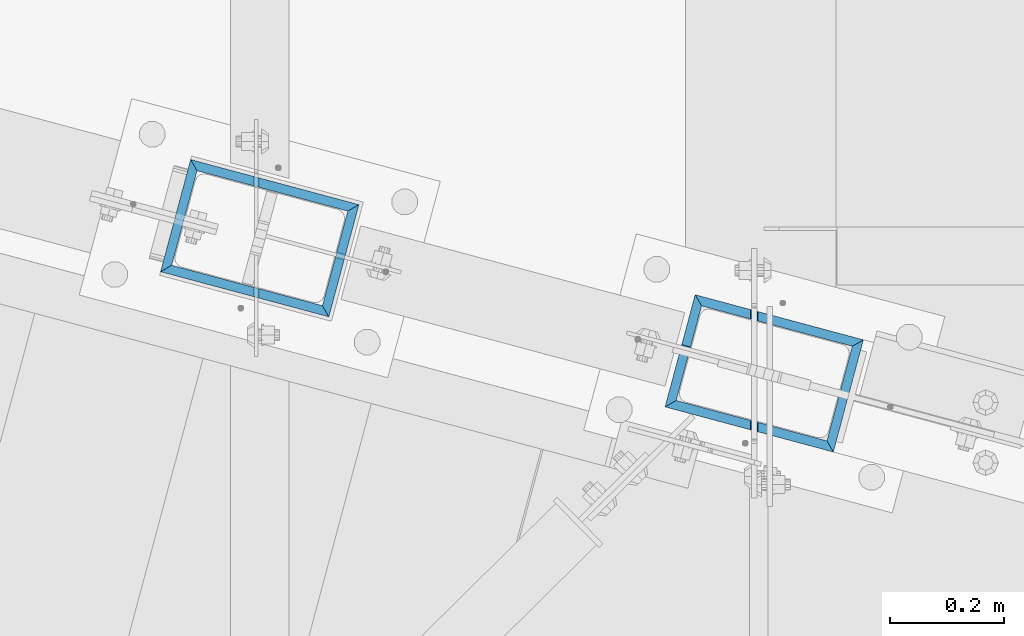
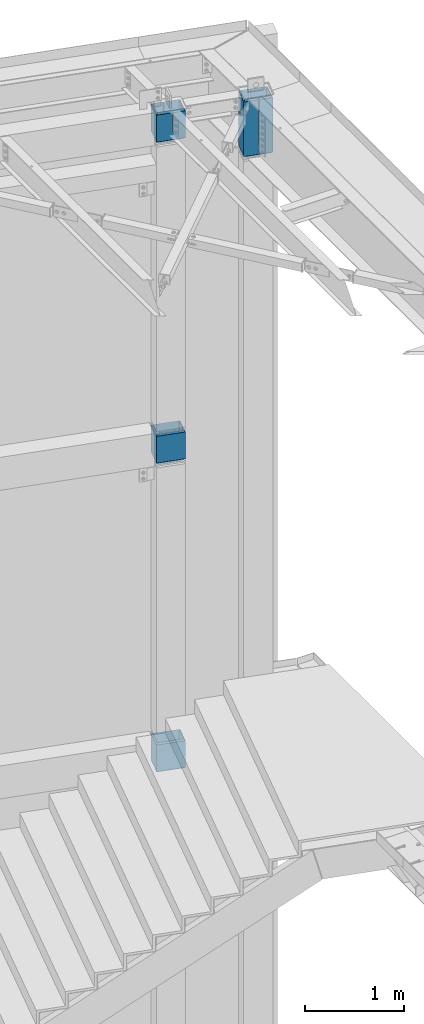
# One storey, part 977 of 1763: 4 columns, 2 elements without a shape of their own.
"""IFC2X3 building model written with IfcOpenShell, lengths in millimetres."""

from ifc_helpers import new_model, si_unit, frame, origin_with_axes, place, context, subcontext, project, spatial, faceted_brep, material, type_object, element, aggregate, save


model = new_model("IFC2X3")

# Units and contexts
model_context = context("Model", 3, precision=1e-05, world=origin_with_axes())
body_context = subcontext(model_context, "Body", "Model", "MODEL_VIEW")
ifc_project = project(units=[si_unit("LENGTHUNIT", "METRE", prefix="MILLI"), si_unit("AREAUNIT", "SQUARE_METRE"), si_unit("VOLUMEUNIT", "CUBIC_METRE"), si_unit("MASSUNIT", "GRAM", prefix="KILO"), si_unit("TIMEUNIT", "SECOND"), si_unit("PLANEANGLEUNIT", "RADIAN"), si_unit("SOLIDANGLEUNIT", "STERADIAN"), si_unit("THERMODYNAMICTEMPERATUREUNIT", "DEGREE_CELSIUS"), si_unit("LUMINOUSINTENSITYUNIT", "LUMEN")], contexts=[model_context])

# Site, building, storey
site_placement = place(None, origin_with_axes())
site = spatial("IfcSite", under=ifc_project, at=site_placement, CompositionType="ELEMENT")
building_placement = place(site_placement, origin_with_axes())
building = spatial("IfcBuilding", under=site, at=building_placement, Name="Undefined", CompositionType="ELEMENT")
storey_placement = place(building_placement, origin_with_axes())
storey = spatial("IfcBuildingStorey", under=building, at=storey_placement, Name="Undefined", CompositionType="ELEMENT", Elevation=0.0)

# Assembly, columns
assembly_1_placement = place(storey_placement, origin_with_axes())
assembly_1 = element("IfcElementAssembly", 1, at=assembly_1_placement, inside=storey, Name="COLUMN", AssemblyPlace="NOTDEFINED", PredefinedType="RIGID_FRAME")
ifc_material = material()
column_type = type_object("IfcColumnType", Name="HSS12X8X5/8", PredefinedType="NOTDEFINED")
column_1_placement = place(assembly_1_placement, frame((-22546.3296169582, 62092.5154188236, 12061.825), z_axis=(-0.965913267114846, 0.258865912030774, 0.0), x_axis=(0.0, 0.0, 1.0)))
column_1 = element("IfcColumn", 2, at=column_1_placement, type_object=column_type, material=ifc_material, Name="COLUMN", ObjectType="HSS12X8X5/8", context=body_context, shape_type="Brep", body=[
    faceted_brep([(365.125000005713, -85.724999991653, 136.524999990441), (349.2499999836, -101.600000015751, 152.399999996545), (349.249999996966, -101.60000000002, -15.7242657489624), (365.125000028824, -85.7250000000276, -11.4697467589649), (365.12499999055, 85.7250000058993, 136.525000005378), (365.12499998278, 85.7249999999331, 34.4790585103037), (349.249999996588, 101.599999999933, 38.7335775331376), (349.249999927195, 101.599999999868, 152.400000000212), (365.125000007893, 11.1191243688081, -136.524999999827), (349.249999997488, 11.1198946284858, -152.399999999834), (349.249999996875, 101.600000000057, -152.399999999776), (365.124999988529, 85.7250000000349, -136.524999999776), (365.124999983111, 85.7249999999331, 24.6179250700661), (349.249999996588, 101.599999999948, 28.8724440929145), (365.125000033029, -85.7249999999549, -136.524999999885), (349.249999997412, -101.599999999933, -152.399999999907), (349.249999997495, 1.59489499857591, -152.399999999841), (365.125000010366, 1.59412473888369, -136.524999999834), (365.125000029155, -85.7250000000204, -21.3308801992025), (349.249999996966, -101.60000000002, -25.5853991891854), (207.962499676918, 1.59412469829113, -136.5249999999), (207.962499661577, 1.59489496210881, -152.3999999999), (206.490806284746, 1.82798829382227, -152.3999999999), (206.490806300088, 1.82721802999004, -136.5249999999), (205.163172509408, 2.50445149033476, -152.3999999999), (205.16317252475, 2.50368122649525, -136.524999999907), (204.109556379663, 3.55806762077555, -152.3999999999), (204.109556395004, 3.55729735695058, -136.524999999907), (203.433093183266, 4.88570139733201, -152.3999999999), (203.433093198608, 4.88493113349978, -136.5249999999), (203.199999851075, 6.35739477576863, -152.3999999999), (203.199999866416, 6.35662451194366, -136.5249999999), (203.433093182502, 7.82908815434348, -152.3999999999), (203.433093197844, 7.82831789051124, -136.5249999999), (204.109556378211, 9.15672193124192, -152.3999999999), (204.109556393552, 9.15595166741696, -136.5249999999), (205.163172507409, 10.2103380622284, -152.3999999999), (205.163172522751, 10.2095677983962, -136.5249999999), (206.490806282394, 10.8868012594176, -152.399999999892), (206.490806297736, 10.8860309955926, -136.524999999892), (207.962499659103, 11.1198945918877, -152.399999999892), (207.962499674444, 11.1191243280628, -136.524999999892), (119.06249371682, 85.7249999999622, 34.4790587648677), (119.062493716812, 101.599999999962, 38.7335777712869), (117.590800339816, 85.7249999999694, 34.2377396544689), (117.590800339809, 101.599999999969, 38.4922586608882), (116.263166563978, 85.7249999999622, 33.5374043161355), (116.263166563969, 101.599999999962, 37.7919233225548), (115.209550433452, 85.7249999999694, 32.4466064523003), (115.209550433443, 101.599999999955, 36.7011254587123), (114.533087236072, 85.7249999999694, 31.0721209579206), (114.533087236063, 101.599999999962, 35.3266399643326), (114.299993902789, 85.7249999999622, 29.5484920497693), (114.29999390278, 101.599999999962, 33.8030110561813), (114.533087233125, 85.7249999999694, 28.024863141145), (114.533087233118, 101.599999999962, 32.279382147557), (115.209550427853, 85.7249999999694, 26.650377645361), (115.209550427844, 101.599999999962, 30.904896651773), (116.263166556268, 85.7249999999694, 25.559579779343), (116.263166556259, 101.599999999962, 29.814098785755), (117.590800330752, 85.7249999999694, 24.8592444382593), (117.590800330743, 101.599999999969, 29.1137634446786), (119.06249370729, 85.7249999999767, 24.6179253248192), (119.062493707281, 101.599999999962, 28.8724443312385), (119.06249982044, -101.599999999999, -15.7242655108203), (119.062499820431, -85.7250000000058, -11.4697465044082), (117.590806443437, -101.599999999991, -15.965584621219), (117.590806443428, -85.7249999999985, -11.7110656147997), (116.263172667599, -101.599999999999, -16.6659199595524), (116.26317266759, -85.7249999999985, -12.4114009531331), (115.209556537073, -101.599999999999, -17.7567178233876), (115.209556537064, -85.7249999999985, -13.5021988169683), (114.533093339693, -101.599999999991, -19.1312033177674), (114.533093339684, -85.7249999999985, -14.8766843113553), (114.300000006409, -101.599999999991, -20.6548322259187), (114.3000000064, -85.7250000000058, -16.4003132194994), (114.533093336746, -101.599999999984, -22.1784611345429), (114.533093336737, -85.7249999999913, -17.9239421281309), (115.209556531472, -101.599999999991, -23.5529466303269), (115.209556531463, -85.7249999999985, -19.2984276239149), (116.263172659888, -101.599999999991, -24.6437444963449), (116.263172659879, -85.7249999999985, -20.3892254899329), (117.590806434373, -101.599999999984, -25.3440798374286), (117.590806434364, -85.7249999999913, -21.0895608310093), (119.062499810911, -101.599999999991, -25.5853989508614), (119.062499810901, -85.7249999999913, -21.3308799444494), (2.6539055397734e-08, -85.7250000000786, 136.524999999943), (-1.79607013706118e-08, 85.7249999999112, 136.525000000052), (3.57213139068335e-08, -85.7249999999112, -136.525000000038), (-8.7784428615123e-09, 85.7250000000786, -136.524999999929), (15.8749997894356, -101.599999999897, -152.400000000045), (15.8749997889863, 101.600000000093, -152.399999999921), (15.8750005575985, 101.599999999904, 152.40000000006), (15.8750003442947, -101.600000343831, 152.399999922112)], [[[0, 1, 2, 3]], [[4, 5, 6, 7]], [[8, 9, 10, 11]], [[12, 11, 10, 13]], [[14, 15, 16, 17]], [[18, 19, 15, 14]], [[20, 21, 22, 23]], [[23, 22, 24, 25]], [[25, 24, 26, 27]], [[27, 26, 28, 29]], [[29, 28, 30, 31]], [[31, 30, 32, 33]], [[33, 32, 34, 35]], [[35, 34, 36, 37]], [[37, 36, 38, 39]], [[39, 38, 40, 41]], [[41, 40, 9, 8]], [[42, 43, 6, 5]], [[43, 42, 44, 45]], [[45, 44, 46, 47]], [[47, 46, 48, 49]], [[49, 48, 50, 51]], [[51, 50, 52, 53]], [[53, 52, 54, 55]], [[55, 54, 56, 57]], [[57, 56, 58, 59]], [[59, 58, 60, 61]], [[61, 60, 62, 63]], [[63, 62, 12, 13]], [[64, 65, 3, 2]], [[65, 64, 66, 67]], [[67, 66, 68, 69]], [[69, 68, 70, 71]], [[71, 70, 72, 73]], [[73, 72, 74, 75]], [[75, 74, 76, 77]], [[77, 76, 78, 79]], [[79, 78, 80, 81]], [[81, 80, 82, 83]], [[83, 82, 84, 85]], [[86, 87, 4, 0]], [[65, 67, 69, 71, 73, 75, 77, 79, 81, 83, 85, 18, 14, 88, 86, 0, 3]], [[20, 23, 25, 27, 29, 31, 33, 35, 37, 39, 41, 8, 11, 89, 88, 14, 17]], [[21, 20, 17, 16]], [[90, 91, 10, 9, 40, 38, 36, 34, 32, 30, 28, 26, 24, 22, 21, 16, 15]], [[43, 45, 47, 49, 51, 53, 55, 57, 59, 61, 63, 13, 10, 91, 92, 7, 6]], [[87, 89, 11, 12, 62, 60, 58, 56, 54, 52, 50, 48, 46, 44, 42, 5, 4]], [[92, 91, 89, 87]], [[90, 88, 89, 91]], [[93, 86, 88, 90]], [[92, 87, 86, 93]], [[92, 93, 1, 7]], [[4, 7, 1, 0]], [[93, 90, 15, 19, 84, 82, 80, 78, 76, 74, 72, 70, 68, 66, 64, 2, 1]], [[85, 84, 19, 18]]]),
])
column_2_placement = place(assembly_1_placement, frame((-22546.3296173738, 62092.515418935, 8093.075), z_axis=(-0.965913267114846, 0.258865912030774, 0.0), x_axis=(0.0, 0.0, 1.0)))
column_2 = element("IfcColumn", 3, at=column_2_placement, type_object=column_type, material=ifc_material, Name="COLUMN", ObjectType="HSS12X8X5/8", context=body_context, shape_type="Brep", body=[
    faceted_brep([(368.299999999998, 85.7249999999112, 136.525000000045), (368.299999999998, 85.7250000000859, -136.524999999936), (352.42499999996, 101.6000000001, -152.399999999929), (352.425000001652, 101.599999999904, 152.40000000006), (368.299999999998, -85.7249999999112, -136.525000000045), (352.42499999998, -101.599999999897, -152.40000000006), (368.299999999991, -85.7250000000931, 136.524999999921), (352.425000001806, -101.600000000064, 152.3999999999), (22.2250001691827, -101.599999999904, -152.40000000006), (6.35000000000036, -85.7249999999112, -136.525000000045), (6.35000000000036, 85.7250000000859, -136.524999999936), (22.22500016919, 101.600000000093, -152.399999999921), (22.2249997738745, -101.599999773942, 152.400000112088), (6.35000000000036, -85.7250000000786, 136.524999999943), (22.2249996600258, 101.599999999904, 152.40000000006), (6.35000000000036, 85.7249999999112, 136.525000000045)], [[[0, 1, 2, 3]], [[4, 5, 2, 1]], [[6, 7, 5, 4]], [[8, 9, 10, 11]], [[12, 13, 9, 8]], [[14, 15, 13, 12]], [[13, 15, 0, 6]], [[9, 13, 6, 4]], [[10, 9, 4, 1]], [[15, 10, 1, 0]], [[14, 11, 10, 15]], [[11, 14, 3, 2]], [[8, 11, 2, 5]], [[12, 8, 5, 7]], [[14, 12, 7, 3]], [[0, 3, 7, 6]]]),
])
column_3_placement = place(assembly_1_placement, frame((-22546.3296173738, 62092.515418935, 4283.075), z_axis=(-0.965913267112463, 0.258865912030139, -2.22073186068884e-06), x_axis=(-2.14500000184509e-06, 5.75000004795221e-07, 0.999999999997534)))
column_3 = element("IfcColumn", 4, at=column_3_placement, type_object=column_type, material=ifc_material, Name="COLUMN", ObjectType="HSS12X8X5/8", context=body_context, shape_type="Brep", body=[
    faceted_brep([(368.299999999998, 85.7249999999112, 136.525000000045), (368.299999999998, 85.7250000000859, -136.524999999936), (352.42499999996, 101.6000000001, -152.399999999929), (352.425000001652, 101.599999999904, 152.40000000006), (368.299999999998, -85.7249999999112, -136.525000000045), (352.42499999998, -101.599999999897, -152.40000000006), (368.299999999991, -85.7250000000931, 136.524999999921), (352.425000001806, -101.600000000064, 152.3999999999), (22.2250001691827, -101.599999999904, -152.40000000006), (6.35000000000036, -85.7249999999112, -136.525000000045), (6.35000000000036, 85.7250000000859, -136.524999999936), (22.22500016919, 101.600000000093, -152.399999999921), (22.2249997738745, -101.599999773942, 152.400000112088), (6.35000000000036, -85.7250000000786, 136.524999999943), (22.2249996600258, 101.599999999904, 152.40000000006), (6.35000000000036, 85.7249999999112, 136.525000000045)], [[[0, 1, 2, 3]], [[4, 5, 2, 1]], [[6, 7, 5, 4]], [[8, 9, 10, 11]], [[12, 13, 9, 8]], [[14, 15, 13, 12]], [[13, 15, 0, 6]], [[9, 13, 6, 4]], [[10, 9, 4, 1]], [[15, 10, 1, 0]], [[14, 11, 10, 15]], [[11, 14, 3, 2]], [[8, 11, 2, 5]], [[12, 8, 5, 7]], [[14, 12, 7, 3]], [[0, 3, 7, 6]]]),
])
aggregate(assembly_1, [column_1, column_2, column_3])

# Assembly, column
assembly_2_placement = place(storey_placement, origin_with_axes())
assembly_2 = element("IfcElementAssembly", 5, at=assembly_2_placement, inside=storey, Name="COLUMN", AssemblyPlace="NOTDEFINED", PredefinedType="RIGID_FRAME")
column_4_placement = place(assembly_2_placement, frame((-21663.6796174499, 61856.0100642813, 11722.1), z_axis=(-0.965913267114846, 0.258865912030774, 0.0), x_axis=(0.0, 0.0, 1.0)))
column_4 = element("IfcColumn", 6, at=column_4_placement, type_object=column_type, material=ifc_material, Name="COLUMN", ObjectType="HSS12X8X5/8", context=body_context, shape_type="Brep", body=[
    faceted_brep([(701.674999999983, -85.7250000000786, 136.524999999929), (685.800000001731, -101.600000000071, 152.399999999921), (685.799999999981, -101.599999999984, -2.56573435622704), (701.674999999997, -85.7249999999913, 1.68878465019225), (701.674999999985, 85.7249999999185, 136.525000000038), (701.674999999997, 85.7249999999694, 47.6375899194609), (685.799999999977, 101.599999999969, 51.8921089258729), (685.800000001591, 101.599999999904, 152.40000000006), (701.674999999997, -85.724999999984, -11.459393598976), (685.799999999981, -101.599999999977, -15.713912605388), (685.79999999997, -101.599999999897, -152.400000000052), (701.674999999997, -85.7249999999112, -136.525000000045), (685.799999999972, 101.6000000001, -152.399999999921), (701.674999999997, 85.7250000000931, -136.524999999929), (701.674999999997, 85.7249999999767, 34.4894116702999), (685.799999999977, 101.599999999977, 38.7439306767119), (-3.17499999999927, 85.7250000000931, -136.524999999929), (-3.17499999999927, -85.7249999999112, -136.525000000045), (52.3874999046311, 85.7249999999694, 47.6375899194609), (52.3874999046311, 101.599999999969, 51.8921089258729), (49.9574601456079, 85.7249999999767, 47.137167181987), (49.9574601456079, 101.599999999969, 51.391686188399), (47.8973719115311, 85.7249999999694, 45.7120837949988), (47.8973719115311, 101.599999999969, 49.9666028014108), (46.5208649612923, 85.7249999999694, 43.5792957857484), (46.5208649612923, 101.599999999969, 47.8338147921677), (46.0374999999985, 85.7249999999694, 41.0635007948804), (46.0374999999985, 101.599999999969, 45.3180198012924), (46.5208649612923, 85.7249999999767, 38.5477058040124), (46.5208649612923, 101.599999999977, 42.8022248104244), (47.8973719115311, 85.7249999999767, 36.414917794762), (47.8973719115311, 101.599999999969, 40.669436801174), (49.9574601456079, 85.724999999984, 34.9898344077737), (49.9574601456079, 101.599999999977, 39.2443534141858), (52.3874999046311, 85.7249999999767, 34.4894116702999), (52.3874999046311, 101.599999999977, 38.7439306767119), (531.812499809263, 1.58087580290157, 136.525000000001), (531.812499809263, 1.58010553907661, 152.399999999929), (685.80000000166, 1.58010553905478, 152.399999999987), (701.674999999997, 1.58087580284337, 136.525000000001), (530.340806432492, 1.81396913499339, 136.525000000001), (530.340806432492, 1.81319887116115, 152.399999999929), (529.013172657331, 2.49043233184057, 136.525000000001), (529.013172657331, 2.4896620680156, 152.399999999929), (527.95955652786, 3.54404846255784, 136.525000000001), (527.95955652786, 3.54327819873288, 152.399999999929), (527.283093331807, 4.87168223928165, 136.525000000001), (527.283093331807, 4.87091197545669, 152.399999999936), (527.049999999997, 6.34337561779103, 136.525000000001), (527.049999999997, 6.34260535396606, 152.399999999936), (527.283093331807, 7.81506899630767, 136.525000000001), (527.283093331807, 7.81429873246816, 152.399999999943), (527.95955652786, 9.14270277303149, 136.525000000009), (527.95955652786, 9.14193250919197, 152.399999999943), (529.013172657331, 10.1963189037415, 136.525000000001), (529.013172657331, 10.1955486399165, 152.399999999943), (530.340806432492, 10.8727821005959, 136.525000000001), (530.340806432492, 10.8720118367637, 152.399999999943), (531.812499809263, 11.1058754326805, 136.525000000009), (531.812499809263, 11.1051051688482, 152.399999999943), (701.674999999997, 11.105875432615, 136.525000000009), (685.800000001653, 11.1051051688264, 152.400000000001), (12.6999999983418, 101.599999999904, 152.40000000006), (-3.17499999999927, 85.7249999999112, 136.525000000052), (-3.17499999999927, -85.7250000000786, 136.524999999943), (12.6999999994241, -101.599999999475, 152.399999999339), (12.7000000000426, -101.599999999897, -152.400000000052), (12.7000000000262, 101.6000000001, -152.399999999921), (52.3874876976006, -85.724999999984, -11.459393598976), (52.3874876976006, -101.599999999708, -15.7139126053153), (49.9574479385774, -85.724999999984, -10.9589708615022), (49.9574479385774, -101.5999999997, -15.2134898678414), (47.8973597045006, -85.724999999984, -9.5338874745139), (47.8973597045006, -101.5999999997, -13.7884064808532), (46.5208527542618, -85.724999999984, -7.40109946525627), (46.5208527542618, -101.5999999997, -11.6556184715955), (46.037487792968, -85.724999999984, -4.88530447439553), (46.037487792968, -101.599999999708, -9.13982348073478), (46.5208527542618, -85.7249999999913, -2.36950948352023), (46.5208527542618, -101.5999999997, -6.62402848985948), (47.8973597045006, -85.7249999999913, -0.236721474277147), (47.8973597045006, -101.5999999997, -4.4912404806164), (49.9574479385774, -85.7249999999913, 1.18836191271112), (49.9574479385774, -101.599999999693, -3.06615709362086), (52.3874876976006, -85.7249999999913, 1.68878465019225), (52.3874876976006, -101.5999999997, -2.565734356147)], [[[0, 1, 2, 3]], [[4, 5, 6, 7]], [[8, 9, 10, 11]], [[11, 10, 12, 13]], [[14, 13, 12, 15]], [[16, 17, 11, 13]], [[18, 19, 6, 5]], [[19, 18, 20, 21]], [[21, 20, 22, 23]], [[23, 22, 24, 25]], [[25, 24, 26, 27]], [[27, 26, 28, 29]], [[29, 28, 30, 31]], [[31, 30, 32, 33]], [[33, 32, 34, 35]], [[35, 34, 14, 15]], [[36, 37, 38, 39]], [[37, 36, 40, 41]], [[41, 40, 42, 43]], [[43, 42, 44, 45]], [[45, 44, 46, 47]], [[47, 46, 48, 49]], [[49, 48, 50, 51]], [[51, 50, 52, 53]], [[53, 52, 54, 55]], [[55, 54, 56, 57]], [[57, 56, 58, 59]], [[59, 58, 60, 61]], [[62, 63, 64, 65]], [[66, 67, 12, 10]], [[68, 69, 9, 8]], [[70, 71, 69, 68]], [[72, 73, 71, 70]], [[74, 75, 73, 72]], [[76, 77, 75, 74]], [[78, 79, 77, 76]], [[80, 81, 79, 78]], [[82, 83, 81, 80]], [[84, 85, 83, 82]], [[85, 84, 3, 2]], [[65, 66, 10, 9, 69, 71, 73, 75, 77, 79, 81, 83, 85, 2, 1]], [[37, 41, 43, 45, 47, 49, 51, 53, 55, 57, 59, 61, 7, 62, 65, 1, 38]], [[19, 21, 23, 25, 27, 29, 31, 33, 35, 15, 12, 67, 62, 7, 6]], [[62, 67, 16, 63]], [[66, 17, 16, 67]], [[65, 64, 17, 66]], [[84, 82, 80, 78, 76, 74, 72, 70, 68, 8, 11, 17, 64, 0, 3]], [[39, 38, 1, 0]], [[64, 63, 4, 60, 58, 56, 54, 52, 50, 48, 46, 44, 42, 40, 36, 39, 0]], [[61, 60, 4, 7]], [[63, 16, 13, 14, 34, 32, 30, 28, 26, 24, 22, 20, 18, 5, 4]]]),
])
aggregate(assembly_2, [column_4])

save(model, "model.ifc")
